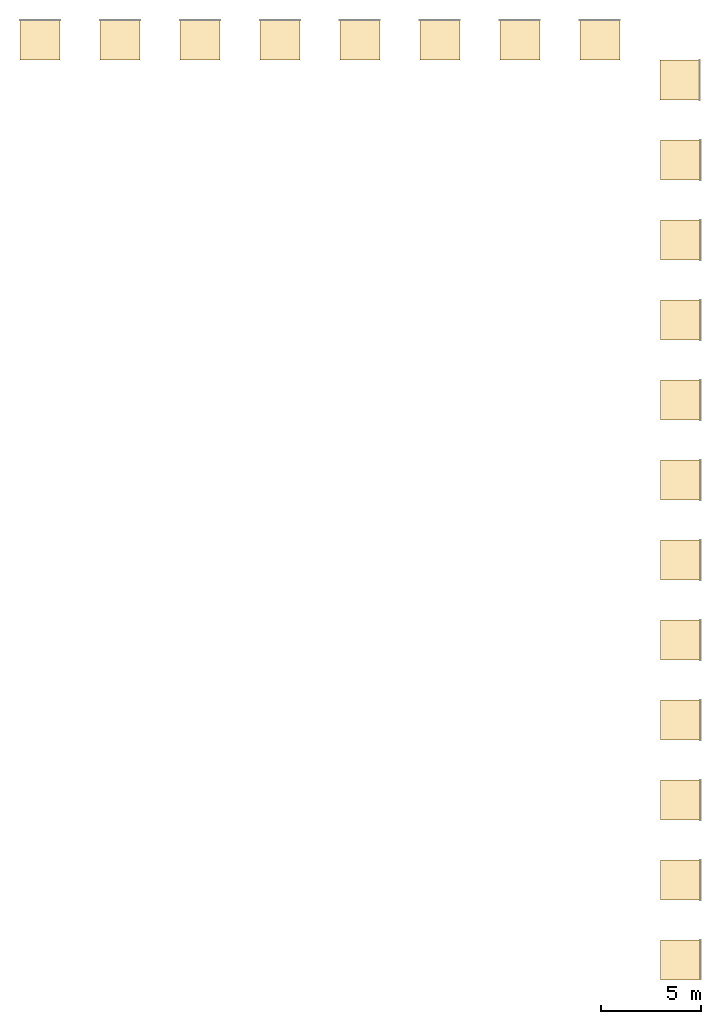
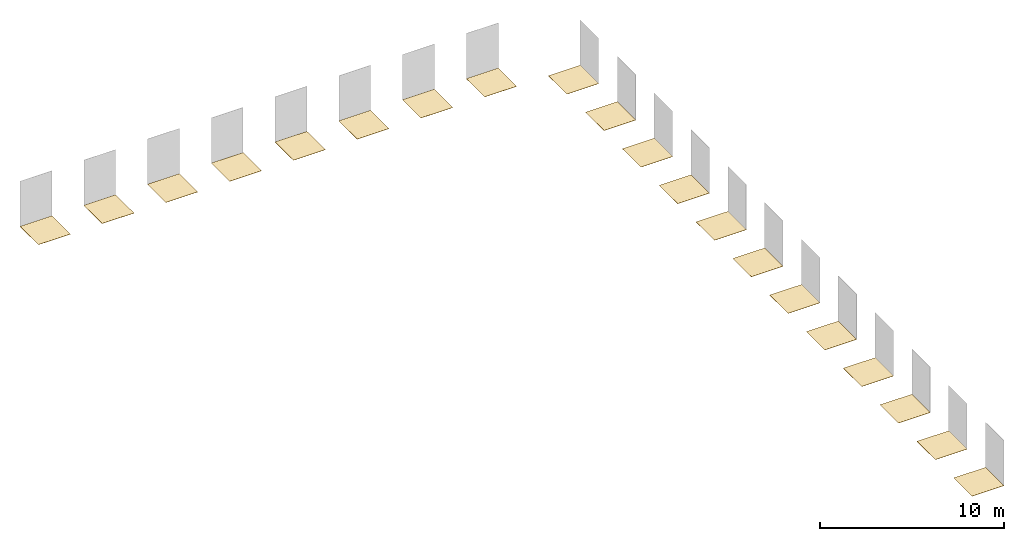
# One storey, part 2 of 2: 20 coverings.
"""IFC2X3 building model written with IfcOpenShell, lengths in millimetres."""

from ifc_helpers import new_model, entity, si_unit, converted_unit, derived_unit, direction, frame, frame_2d, origin, origin_2d_with_axis, place, context, subcontext, project, spatial, rectangle, extrude, material, layer, layer_set, layer_usage, element, save


model = new_model("IFC2X3")

# Units and contexts
model_context = context("Model", 3, precision=0.01, world=origin(), true_north=direction((6.12303176911189e-17, 1.0)))
body_context = subcontext(model_context, "Body", "Model", "MODEL_VIEW")
ifc_project = project(units=[si_unit("LENGTHUNIT", "METRE", prefix="MILLI"), si_unit("AREAUNIT", "SQUARE_METRE"), si_unit("VOLUMEUNIT", "CUBIC_METRE"), converted_unit("PLANEANGLEUNIT", "DEGREE", entity("IfcRatioMeasure", 0.0174532925199433), si_unit("PLANEANGLEUNIT", "RADIAN"), dimensions=[0, 0, 0, 0, 0, 0, 0]), si_unit("MASSUNIT", "GRAM", prefix="KILO"), derived_unit("MASSDENSITYUNIT", [(si_unit("MASSUNIT", "GRAM", prefix="KILO"), 1), (si_unit("LENGTHUNIT", "METRE"), -3)]), si_unit("TIMEUNIT", "SECOND"), si_unit("FREQUENCYUNIT", "HERTZ"), si_unit("THERMODYNAMICTEMPERATUREUNIT", "DEGREE_CELSIUS"), derived_unit("THERMALTRANSMITTANCEUNIT", [(si_unit("MASSUNIT", "GRAM", prefix="KILO"), 1), (si_unit("THERMODYNAMICTEMPERATUREUNIT", "KELVIN"), -1), (si_unit("TIMEUNIT", "SECOND"), -3)]), derived_unit("VOLUMETRICFLOWRATEUNIT", [(si_unit("LENGTHUNIT", "METRE"), 3), (si_unit("TIMEUNIT", "SECOND"), -1)]), si_unit("ELECTRICCURRENTUNIT", "AMPERE"), si_unit("ELECTRICVOLTAGEUNIT", "VOLT"), si_unit("POWERUNIT", "WATT"), si_unit("FORCEUNIT", "NEWTON", prefix="KILO"), si_unit("ILLUMINANCEUNIT", "LUX"), si_unit("LUMINOUSFLUXUNIT", "LUMEN"), si_unit("LUMINOUSINTENSITYUNIT", "CANDELA"), derived_unit("USERDEFINED", [(si_unit("MASSUNIT", "GRAM", prefix="KILO"), -1), (si_unit("LENGTHUNIT", "METRE"), -2), (si_unit("TIMEUNIT", "SECOND"), 3), (si_unit("LUMINOUSFLUXUNIT", "LUMEN"), 1)]), derived_unit("LINEARVELOCITYUNIT", [(si_unit("LENGTHUNIT", "METRE"), 1), (si_unit("TIMEUNIT", "SECOND"), -1)]), si_unit("PRESSUREUNIT", "PASCAL"), derived_unit("USERDEFINED", [(si_unit("LENGTHUNIT", "METRE"), -2), (si_unit("MASSUNIT", "GRAM", prefix="KILO"), 1), (si_unit("TIMEUNIT", "SECOND"), -2)])], contexts=[model_context])

# Site, building, storey
site_placement = place(None, origin())
site = spatial("IfcSite", under=ifc_project, at=site_placement, CompositionType="ELEMENT")
building_placement = place(site_placement, origin())
building = spatial("IfcBuilding", under=site, at=building_placement, CompositionType="ELEMENT")
storey_placement = place(building_placement, origin())
storey = spatial("IfcBuildingStorey", under=building, at=storey_placement, Name="Level 1", CompositionType="ELEMENT", Elevation=0.0)

# Coverings
ifc_material_1 = material(Name="PGR_CeramicTiles_Acero-193x1200mm")
ifc_layer_1 = layer(ifc_material_1, 11.5)
ifc_layer_set_1 = layer_set([ifc_layer_1], Name="Floor:PGR_CeramicTiles_Acero-193x1200mm")
ifc_layer_usage_1 = layer_usage(ifc_layer_set_1, "AXIS3", "POSITIVE", 0.0)
covering_1_placement = place(storey_placement, origin())
element("IfcCovering", 1, at=covering_1_placement, inside=storey, material=ifc_layer_usage_1, Name="Floor:PGR_CeramicTiles_Acero-193x1200mm", ObjectType="Floor:PGR_CeramicTiles_Acero-193x1200mm", PredefinedType="FLOORING", context=body_context, shape_type="SweptSolid", body=[
    extrude(rectangle(XDim=2000.0, YDim=2000.0, at=frame_2d((2.1600499167107e-12, 1.13686837721616e-13), x_axis=(1.0, 0.0))), frame((2527.07742659015, 24498.0173252312, 0.0), z_axis=(0.0, 0.0, -1.0), x_axis=(0.0, 1.0, 0.0)), (0.0, 0.0, 1.0), 11.5),
])
ifc_material_2 = material(Name="PGR_CeramicTiles_Acero-193x1800mm")
ifc_layer_2 = layer(ifc_material_2, 11.5)
ifc_layer_set_2 = layer_set([ifc_layer_2], Name="Floor:PGR_CeramicTiles_Acero-193x1800mm")
ifc_layer_usage_2 = layer_usage(ifc_layer_set_2, "AXIS3", "POSITIVE", 0.0)
covering_2_placement = place(storey_placement, origin())
element("IfcCovering", 2, at=covering_2_placement, inside=storey, material=ifc_layer_usage_2, Name="Floor:PGR_CeramicTiles_Acero-193x1800mm", ObjectType="Floor:PGR_CeramicTiles_Acero-193x1800mm", PredefinedType="FLOORING", context=body_context, shape_type="SweptSolid", body=[
    extrude(rectangle(XDim=2000.0, YDim=2000.0, at=frame_2d((-2.1600499167107e-12, 1.13686837721616e-13), x_axis=(1.0, 0.0))), frame((2527.07742659015, 28498.0173252312, 0.0), z_axis=(0.0, 0.0, -1.0), x_axis=(0.0, 1.0, 0.0)), (0.0, 0.0, 1.0), 11.5),
])
ifc_material_3 = material(Name="PGR_CeramicTiles_Acero-294x1200mm")
ifc_layer_3 = layer(ifc_material_3, 11.5)
ifc_layer_set_3 = layer_set([ifc_layer_3], Name="Floor:PGR_CeramicTiles_Acero-294x1200mm")
ifc_layer_usage_3 = layer_usage(ifc_layer_set_3, "AXIS3", "POSITIVE", 0.0)
covering_3_placement = place(storey_placement, origin())
element("IfcCovering", 3, at=covering_3_placement, inside=storey, material=ifc_layer_usage_3, Name="Floor:PGR_CeramicTiles_Acero-294x1200mm", ObjectType="Floor:PGR_CeramicTiles_Acero-294x1200mm", PredefinedType="FLOORING", context=body_context, shape_type="SweptSolid", body=[
    extrude(rectangle(XDim=2000.0, YDim=2000.0, at=frame_2d((0.0, 5.6843418860808e-13), x_axis=(1.0, 0.0))), frame((-1498.42257340995, 70498.0173252312, 0.0), z_axis=(0.0, 0.0, -1.0), x_axis=(0.0, 1.0, 0.0)), (0.0, 0.0, 1.0), 11.5),
])
ifc_material_4 = material(Name="PGR_CeramicTiles_Acero-294x1800mm")
ifc_layer_4 = layer(ifc_material_4, 11.5)
ifc_layer_set_4 = layer_set([ifc_layer_4], Name="Floor:PGR_CeramicTiles_Acero-294x1800mm")
ifc_layer_usage_4 = layer_usage(ifc_layer_set_4, "AXIS3", "POSITIVE", 0.0)
covering_4_placement = place(storey_placement, origin())
element("IfcCovering", 4, at=covering_4_placement, inside=storey, material=ifc_layer_usage_4, Name="Floor:PGR_CeramicTiles_Acero-294x1800mm", ObjectType="Floor:PGR_CeramicTiles_Acero-294x1800mm", PredefinedType="FLOORING", context=body_context, shape_type="SweptSolid", body=[
    extrude(rectangle(XDim=2000.0, YDim=2000.0, at=frame_2d((0.0, 2.27373675443232e-13), x_axis=(1.0, 0.0))), frame((-5498.42257340995, 70498.0173252312, 0.0), z_axis=(0.0, 0.0, -1.0), x_axis=(0.0, 1.0, 0.0)), (0.0, 0.0, 1.0), 11.5),
])
ifc_material_5 = material(Name="PGR_CeramicTiles_Acero_Ant.-193x1800mm")
ifc_layer_5 = layer(ifc_material_5, 11.5)
ifc_layer_set_5 = layer_set([ifc_layer_5], Name="Floor:PGR_CeramicTiles_Acero_Ant.-193x1800mm")
ifc_layer_usage_5 = layer_usage(ifc_layer_set_5, "AXIS3", "POSITIVE", 0.0)
covering_5_placement = place(storey_placement, origin())
element("IfcCovering", 5, at=covering_5_placement, inside=storey, material=ifc_layer_usage_5, Name="Floor:PGR_CeramicTiles_Acero_Ant.-193x1800mm", ObjectType="Floor:PGR_CeramicTiles_Acero_Ant.-193x1800mm", PredefinedType="FLOORING", context=body_context, shape_type="SweptSolid", body=[
    extrude(rectangle(XDim=2000.0, YDim=2000.0, at=frame_2d((-2.1600499167107e-12, 1.13686837721616e-13), x_axis=(1.0, 0.0))), frame((2527.07742659013, 32498.0173252312, 0.0), z_axis=(0.0, 0.0, -1.0), x_axis=(0.0, 1.0, 0.0)), (0.0, 0.0, 1.0), 11.5),
])
ifc_material_6 = material(Name="PGR_CeramicTiles_Arce-193x1200mm")
ifc_layer_6 = layer(ifc_material_6, 11.5)
ifc_layer_set_6 = layer_set([ifc_layer_6], Name="Floor:PGR_CeramicTiles_Arce-193x1200mm")
ifc_layer_usage_6 = layer_usage(ifc_layer_set_6, "AXIS3", "POSITIVE", 0.0)
covering_6_placement = place(storey_placement, origin())
element("IfcCovering", 6, at=covering_6_placement, inside=storey, material=ifc_layer_usage_6, Name="Floor:PGR_CeramicTiles_Arce-193x1200mm", ObjectType="Floor:PGR_CeramicTiles_Arce-193x1200mm", PredefinedType="FLOORING", context=body_context, shape_type="SweptSolid", body=[
    extrude(rectangle(XDim=2000.0, YDim=2000.0, at=frame_2d((2.1600499167107e-12, 1.13686837721616e-13), x_axis=(1.0, 0.0))), frame((2527.07742659013, 36498.0173252312, 0.0), z_axis=(0.0, 0.0, -1.0), x_axis=(0.0, 1.0, 0.0)), (0.0, 0.0, 1.0), 11.5),
])
ifc_material_7 = material(Name="PGR_CeramicTiles_Arce-193x1800mm")
ifc_layer_7 = layer(ifc_material_7, 11.5)
ifc_layer_set_7 = layer_set([ifc_layer_7], Name="Floor:PGR_CeramicTiles_Arce-193x1800mm")
ifc_layer_usage_7 = layer_usage(ifc_layer_set_7, "AXIS3", "POSITIVE", 0.0)
covering_7_placement = place(storey_placement, origin())
element("IfcCovering", 7, at=covering_7_placement, inside=storey, material=ifc_layer_usage_7, Name="Floor:PGR_CeramicTiles_Arce-193x1800mm", ObjectType="Floor:PGR_CeramicTiles_Arce-193x1800mm", PredefinedType="FLOORING", context=body_context, shape_type="SweptSolid", body=[
    extrude(rectangle(XDim=2000.0, YDim=2000.0, at=frame_2d((-4.32009983342141e-12, 1.13686837721616e-13), x_axis=(1.0, 0.0))), frame((2527.07742659013, 40498.0173252312, 0.0), z_axis=(0.0, 0.0, -1.0), x_axis=(0.0, 1.0, 0.0)), (0.0, 0.0, 1.0), 11.5),
])
ifc_material_8 = material(Name="PGR_CeramicTiles_Arce-294x1200mm")
ifc_layer_8 = layer(ifc_material_8, 11.5)
ifc_layer_set_8 = layer_set([ifc_layer_8], Name="Floor:PGR_CeramicTiles_Arce-294x1200mm")
ifc_layer_usage_8 = layer_usage(ifc_layer_set_8, "AXIS3", "POSITIVE", 0.0)
covering_8_placement = place(storey_placement, origin())
element("IfcCovering", 8, at=covering_8_placement, inside=storey, material=ifc_layer_usage_8, Name="Floor:PGR_CeramicTiles_Arce-294x1200mm", ObjectType="Floor:PGR_CeramicTiles_Arce-294x1200mm", PredefinedType="FLOORING", context=body_context, shape_type="SweptSolid", body=[
    extrude(rectangle(XDim=2000.0, YDim=2000.0, at=frame_2d((0.0, -1.08002495835535e-12), x_axis=(1.0, 0.0))), frame((-9498.42257340995, 70498.0173252312, 0.0), z_axis=(0.0, 0.0, -1.0), x_axis=(0.0, 1.0, 0.0)), (0.0, 0.0, 1.0), 11.5),
])
ifc_material_9 = material(Name="PGR_CeramicTiles_Arce-294x1800mm")
ifc_layer_9 = layer(ifc_material_9, 11.5)
ifc_layer_set_9 = layer_set([ifc_layer_9], Name="Floor:PGR_CeramicTiles_Arce-294x1800mm")
ifc_layer_usage_9 = layer_usage(ifc_layer_set_9, "AXIS3", "POSITIVE", 0.0)
covering_9_placement = place(storey_placement, origin())
element("IfcCovering", 9, at=covering_9_placement, inside=storey, material=ifc_layer_usage_9, Name="Floor:PGR_CeramicTiles_Arce-294x1800mm", ObjectType="Floor:PGR_CeramicTiles_Arce-294x1800mm", PredefinedType="FLOORING", context=body_context, shape_type="SweptSolid", body=[
    extrude(rectangle(XDim=2000.0, YDim=2000.0, at=origin_2d_with_axis()), frame((-13498.42257341, 70498.0173252312, 0.0), z_axis=(0.0, 0.0, -1.0), x_axis=(0.0, 1.0, 0.0)), (0.0, 0.0, 1.0), 11.5),
])
ifc_material_10 = material(Name="PGR_CeramicTiles_Arce_Ant.-193x1800mm")
ifc_layer_10 = layer(ifc_material_10, 11.5)
ifc_layer_set_10 = layer_set([ifc_layer_10], Name="Floor:PGR_CeramicTiles_Arce_Ant.-193x1800mm")
ifc_layer_usage_10 = layer_usage(ifc_layer_set_10, "AXIS3", "POSITIVE", 0.0)
covering_10_placement = place(storey_placement, origin())
element("IfcCovering", 10, at=covering_10_placement, inside=storey, material=ifc_layer_usage_10, Name="Floor:PGR_CeramicTiles_Arce_Ant.-193x1800mm", ObjectType="Floor:PGR_CeramicTiles_Arce_Ant.-193x1800mm", PredefinedType="FLOORING", context=body_context, shape_type="SweptSolid", body=[
    extrude(rectangle(XDim=2000.0, YDim=2000.0, at=frame_2d((-4.32009983342141e-12, 1.13686837721616e-13), x_axis=(1.0, 0.0))), frame((2527.07742659012, 44498.0173252312, 0.0), z_axis=(0.0, 0.0, -1.0), x_axis=(0.0, 1.0, 0.0)), (0.0, 0.0, 1.0), 11.5),
])
ifc_material_11 = material(Name="PGR_CeramicTiles_Natural-193x1200mm")
ifc_layer_11 = layer(ifc_material_11, 11.5)
ifc_layer_set_11 = layer_set([ifc_layer_11], Name="Floor:PGR_CeramicTiles_Natural-193x1200mm")
ifc_layer_usage_11 = layer_usage(ifc_layer_set_11, "AXIS3", "POSITIVE", 0.0)
covering_11_placement = place(storey_placement, origin())
element("IfcCovering", 11, at=covering_11_placement, inside=storey, material=ifc_layer_usage_11, Name="Floor:PGR_CeramicTiles_Natural-193x1200mm", ObjectType="Floor:PGR_CeramicTiles_Natural-193x1200mm", PredefinedType="FLOORING", context=body_context, shape_type="SweptSolid", body=[
    extrude(rectangle(XDim=2000.0, YDim=2000.00000000002, at=frame_2d((4.32009983342141e-12, 0.0), x_axis=(1.0, 0.0))), frame((2527.07742659013, 48498.0173252312, 0.0), z_axis=(0.0, 0.0, -1.0), x_axis=(0.0, 1.0, 0.0)), (0.0, 0.0, 1.0), 11.5),
])
ifc_material_12 = material(Name="PGR_CeramicTiles_Natural-193x1800mm")
ifc_layer_12 = layer(ifc_material_12, 11.5)
ifc_layer_set_12 = layer_set([ifc_layer_12], Name="Floor:PGR_CeramicTiles_Natural-193x1800mm")
ifc_layer_usage_12 = layer_usage(ifc_layer_set_12, "AXIS3", "POSITIVE", 0.0)
covering_12_placement = place(storey_placement, origin())
element("IfcCovering", 12, at=covering_12_placement, inside=storey, material=ifc_layer_usage_12, Name="Floor:PGR_CeramicTiles_Natural-193x1800mm", ObjectType="Floor:PGR_CeramicTiles_Natural-193x1800mm", PredefinedType="FLOORING", context=body_context, shape_type="SweptSolid", body=[
    extrude(rectangle(XDim=2000.0, YDim=2000.00000000001, at=frame_2d((4.32009983342141e-12, 0.0), x_axis=(1.0, 0.0))), frame((2527.07742659013, 52498.0173252312, 0.0), z_axis=(0.0, 0.0, -1.0), x_axis=(0.0, 1.0, 0.0)), (0.0, 0.0, 1.0), 11.5),
])
ifc_material_13 = material(Name="PGR_CeramicTiles_Natural-294x1200mm")
ifc_layer_13 = layer(ifc_material_13, 11.5)
ifc_layer_set_13 = layer_set([ifc_layer_13], Name="Floor:PGR_CeramicTiles_Natural-294x1200mm")
ifc_layer_usage_13 = layer_usage(ifc_layer_set_13, "AXIS3", "POSITIVE", 0.0)
covering_13_placement = place(storey_placement, origin())
element("IfcCovering", 13, at=covering_13_placement, inside=storey, material=ifc_layer_usage_13, Name="Floor:PGR_CeramicTiles_Natural-294x1200mm", ObjectType="Floor:PGR_CeramicTiles_Natural-294x1200mm", PredefinedType="FLOORING", context=body_context, shape_type="SweptSolid", body=[
    extrude(rectangle(XDim=2000.0, YDim=2000.0, at=frame_2d((4.32009983342141e-12, 2.1600499167107e-12), x_axis=(1.0, 0.0))), frame((-17498.4225734099, 70498.0173252311, 0.0), z_axis=(0.0, 0.0, -1.0), x_axis=(0.0, 1.0, 0.0)), (0.0, 0.0, 1.0), 11.5),
])
ifc_material_14 = material(Name="PGR_CeramicTiles_Natural-294x1800mm")
ifc_layer_14 = layer(ifc_material_14, 11.5)
ifc_layer_set_14 = layer_set([ifc_layer_14], Name="Floor:PGR_CeramicTiles_Natural-294x1800mm")
ifc_layer_usage_14 = layer_usage(ifc_layer_set_14, "AXIS3", "POSITIVE", 0.0)
covering_14_placement = place(storey_placement, origin())
element("IfcCovering", 14, at=covering_14_placement, inside=storey, material=ifc_layer_usage_14, Name="Floor:PGR_CeramicTiles_Natural-294x1800mm", ObjectType="Floor:PGR_CeramicTiles_Natural-294x1800mm", PredefinedType="FLOORING", context=body_context, shape_type="SweptSolid", body=[
    extrude(rectangle(XDim=2000.0, YDim=2000.0, at=frame_2d((4.32009983342141e-12, 0.0), x_axis=(1.0, 0.0))), frame((-21498.4225734099, 70498.0173252312, 0.0), z_axis=(0.0, 0.0, -1.0), x_axis=(0.0, 1.0, 0.0)), (0.0, 0.0, 1.0), 11.5),
])
ifc_material_15 = material(Name="PGR_CeramicTiles_Natural_Ant.-193x1800mm")
ifc_layer_15 = layer(ifc_material_15, 11.5)
ifc_layer_set_15 = layer_set([ifc_layer_15], Name="Floor:PGR_CeramicTiles_Natural_Ant.-193x1800mm")
ifc_layer_usage_15 = layer_usage(ifc_layer_set_15, "AXIS3", "POSITIVE", 0.0)
covering_15_placement = place(storey_placement, origin())
element("IfcCovering", 15, at=covering_15_placement, inside=storey, material=ifc_layer_usage_15, Name="Floor:PGR_CeramicTiles_Natural_Ant.-193x1800mm", ObjectType="Floor:PGR_CeramicTiles_Natural_Ant.-193x1800mm", PredefinedType="FLOORING", context=body_context, shape_type="SweptSolid", body=[
    extrude(rectangle(XDim=2000.00000000001, YDim=2000.00000000002, at=frame_2d((-4.32009983342141e-12, 0.0), x_axis=(1.0, 0.0))), frame((2527.07742659014, 56498.0173252312, 0.0), z_axis=(0.0, 0.0, -1.0), x_axis=(0.0, 1.0, 0.0)), (0.0, 0.0, 1.0), 11.5),
])
ifc_material_16 = material(Name="PGR_CeramicTiles_193x1200mm")
ifc_layer_16 = layer(ifc_material_16, 11.5)
ifc_layer_set_16 = layer_set([ifc_layer_16], Name="Floor:PGR_CeramicTiles_193x1200mm")
ifc_layer_usage_16 = layer_usage(ifc_layer_set_16, "AXIS3", "POSITIVE", 0.0)
covering_16_placement = place(storey_placement, origin())
element("IfcCovering", 16, at=covering_16_placement, inside=storey, material=ifc_layer_usage_16, Name="Floor:PGR_CeramicTiles_193x1200mm", ObjectType="Floor:PGR_CeramicTiles_193x1200mm", PredefinedType="FLOORING", context=body_context, shape_type="SweptSolid", body=[
    extrude(rectangle(XDim=2000.00000000001, YDim=2000.00000000001, at=frame_2d((-4.32009983342141e-12, 0.0), x_axis=(1.0, 0.0))), frame((2527.07742659014, 60498.0173252312, 0.0), z_axis=(0.0, 0.0, -1.0), x_axis=(0.0, 1.0, 0.0)), (0.0, 0.0, 1.0), 11.5),
])
ifc_material_17 = material(Name="PGR_CeramicTiles_193x1800mm")
ifc_layer_17 = layer(ifc_material_17, 11.5)
ifc_layer_set_17 = layer_set([ifc_layer_17], Name="Floor:PGR_CeramicTiles_193x1800mm")
ifc_layer_usage_17 = layer_usage(ifc_layer_set_17, "AXIS3", "POSITIVE", 0.0)
covering_17_placement = place(storey_placement, origin())
element("IfcCovering", 17, at=covering_17_placement, inside=storey, material=ifc_layer_usage_17, Name="Floor:PGR_CeramicTiles_193x1800mm", ObjectType="Floor:PGR_CeramicTiles_193x1800mm", PredefinedType="FLOORING", context=body_context, shape_type="SweptSolid", body=[
    extrude(rectangle(XDim=2000.00000000004, YDim=1999.99999999999, at=frame_2d((-4.32009983342141e-12, 2.8421709430404e-13), x_axis=(1.0, 0.0))), frame((2527.07742659016, 64498.0173252312, 0.0), z_axis=(0.0, 0.0, -1.0), x_axis=(0.0, 1.0, 0.0)), (0.0, 0.0, 1.0), 11.5),
])
ifc_material_18 = material(Name="PGR_CeramicTiles_294x1200mm")
ifc_layer_18 = layer(ifc_material_18, 11.5)
ifc_layer_set_18 = layer_set([ifc_layer_18], Name="Floor:PGR_CeramicTiles_294x1200mm")
ifc_layer_usage_18 = layer_usage(ifc_layer_set_18, "AXIS3", "POSITIVE", 0.0)
covering_18_placement = place(storey_placement, origin())
element("IfcCovering", 18, at=covering_18_placement, inside=storey, material=ifc_layer_usage_18, Name="Floor:PGR_CeramicTiles_294x1200mm", ObjectType="Floor:PGR_CeramicTiles_294x1200mm", PredefinedType="FLOORING", context=body_context, shape_type="SweptSolid", body=[
    extrude(rectangle(XDim=2000.0, YDim=2000.0, at=frame_2d((4.32009983342141e-12, 0.0), x_axis=(1.0, 0.0))), frame((-25498.4225734099, 70498.0173252311, 0.0), z_axis=(0.0, 0.0, -1.0), x_axis=(0.0, 1.0, 0.0)), (0.0, 0.0, 1.0), 11.5),
])
ifc_material_19 = material(Name="PGR_CeramicTiles_294x1800mm")
ifc_layer_19 = layer(ifc_material_19, 11.5)
ifc_layer_set_19 = layer_set([ifc_layer_19], Name="Floor:PGR_CeramicTiles_294x1800mm")
ifc_layer_usage_19 = layer_usage(ifc_layer_set_19, "AXIS3", "POSITIVE", 0.0)
covering_19_placement = place(storey_placement, origin())
element("IfcCovering", 19, at=covering_19_placement, inside=storey, material=ifc_layer_usage_19, Name="Floor:PGR_CeramicTiles_294x1800mm", ObjectType="Floor:PGR_CeramicTiles_294x1800mm", PredefinedType="FLOORING", context=body_context, shape_type="SweptSolid", body=[
    extrude(rectangle(XDim=2000.00000000001, YDim=2000.0, at=frame_2d((0.0, -4.32009983342141e-12), x_axis=(1.0, 0.0))), frame((-29498.4225734099, 70498.0173252312, 0.0), z_axis=(0.0, 0.0, -1.0), x_axis=(0.0, 1.0, 0.0)), (0.0, 0.0, 1.0), 11.5),
])
ifc_material_20 = material(Name="PGR_CeramicTiles_Ant.-193x1800mm")
ifc_layer_20 = layer(ifc_material_20, 11.5)
ifc_layer_set_20 = layer_set([ifc_layer_20], Name="Floor:PGR_CeramicTiles_Ant.-193x1800mm")
ifc_layer_usage_20 = layer_usage(ifc_layer_set_20, "AXIS3", "POSITIVE", 0.0)
covering_20_placement = place(storey_placement, origin())
element("IfcCovering", 20, at=covering_20_placement, inside=storey, material=ifc_layer_usage_20, Name="Floor:PGR_CeramicTiles_Ant.-193x1800mm", ObjectType="Floor:PGR_CeramicTiles_Ant.-193x1800mm", PredefinedType="FLOORING", context=body_context, shape_type="SweptSolid", body=[
    extrude(rectangle(XDim=2000.0, YDim=2000.00000000001, at=frame_2d((-4.37694325228222e-12, 0.0), x_axis=(1.0, 0.0))), frame((2501.57742659005, 68498.0173252312, 0.0), z_axis=(0.0, 0.0, -1.0), x_axis=(0.0, 1.0, 0.0)), (0.0, 0.0, 1.0), 11.5),
])

save(model, "model.ifc")
